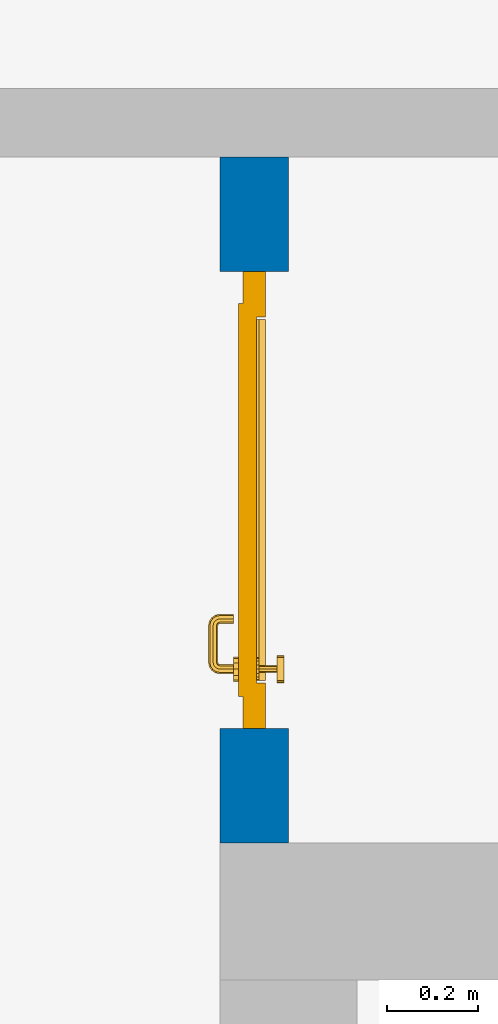
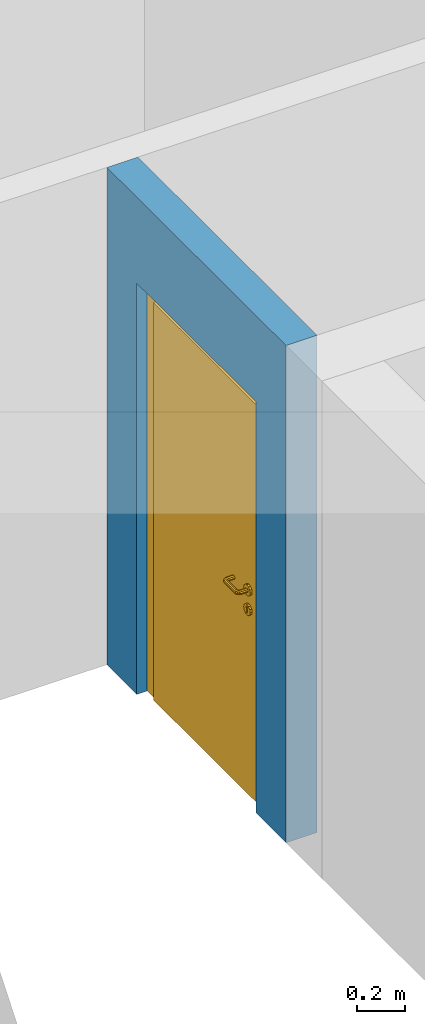
# One storey, part 6 of 54: 1 door, 1 wall, 1 opening.
"""IFC4 building model written with IfcOpenShell, lengths in metres."""

from ifc_helpers import new_model, entity, si_unit, converted_unit, derived_unit, direction, frame, origin_with_axes, place, context, subcontext, project, spatial, polygons, source, transform, mapped, material, type_object, element, fill, save


model = new_model("IFC4")

# Units and contexts
model_context = context("Model", 3, precision=1e-05, world=origin_with_axes(), true_north=direction((0.0, 1.0)))
body_context = subcontext(model_context, "Body", "Model", "MODEL_VIEW")
ifc_project = project(units=[si_unit("LENGTHUNIT", "METRE"), si_unit("AREAUNIT", "SQUARE_METRE"), si_unit("VOLUMEUNIT", "CUBIC_METRE"), converted_unit("PLANEANGLEUNIT", "DEGREE", entity("IfcPlaneAngleMeasure", 0.0174532925199), si_unit("PLANEANGLEUNIT", "RADIAN"), dimensions=[0, 0, 0, 0, 0, 0, 0]), converted_unit("TIMEUNIT", "Year", entity("IfcTimeMeasure", 31556926.0), si_unit("TIMEUNIT", "SECOND"), dimensions=[0, 0, 1, 0, 0, 0, 0]), si_unit("MASSUNIT", "GRAM", prefix="KILO"), si_unit("THERMODYNAMICTEMPERATUREUNIT", "DEGREE_CELSIUS"), si_unit("LUMINOUSINTENSITYUNIT", "LUMEN"), si_unit("ENERGYUNIT", "JOULE", prefix="MEGA"), derived_unit("THERMALCONDUCTANCEUNIT", [(si_unit("POWERUNIT", "WATT"), 1), (si_unit("LENGTHUNIT", "METRE"), -1), (si_unit("THERMODYNAMICTEMPERATUREUNIT", "KELVIN"), -1)]), derived_unit("SPECIFICHEATCAPACITYUNIT", [(si_unit("ENERGYUNIT", "JOULE"), 1), (si_unit("MASSUNIT", "GRAM", prefix="KILO"), -1), (si_unit("THERMODYNAMICTEMPERATUREUNIT", "KELVIN"), -1)]), derived_unit("MASSDENSITYUNIT", [(si_unit("MASSUNIT", "GRAM", prefix="KILO"), 1), (si_unit("VOLUMEUNIT", "CUBIC_METRE"), -1)])], contexts=[model_context])

# Site, building, storey
site_placement = place(None, origin_with_axes())
site = spatial("IfcSite", under=ifc_project, at=site_placement, CompositionType="ELEMENT")
building_placement = place(site_placement, origin_with_axes())
building = spatial("IfcBuilding", under=site, at=building_placement, CompositionType="ELEMENT")
storey_placement = place(building_placement, frame((0.0, 0.0, 6.29), z_axis=(0.0, 0.0, 1.0), x_axis=(1.0, 0.0, 0.0)))
storey = spatial("IfcBuildingStorey", under=building, at=storey_placement, Name="2. Geschoss", CompositionType="ELEMENT", Elevation=6.29)

# Wall, opening, door
ifc_material = material()
wall_type = type_object("IfcWallType", Name="150", PredefinedType="NOTDEFINED")
wall_placement = place(storey_placement, frame((-2.7421993804, 3.67118776896, 0.0), z_axis=(0.0, 0.0, 1.0), x_axis=(0.0, 1.0, 0.0)))
wall = element("IfcWall", 1, at=wall_placement, inside=storey, type_object=wall_type, material=ifc_material, Name="Wand-002", PredefinedType="NOTDEFINED", context=body_context, shape_type="Tessellation", body=[
    polygons([(0.55, -0.15, 2.1), (0.55, 0.0, 2.1), (1.55, 0.0, 2.1), (1.55, -0.15, 2.1), (0.55, -0.1, 0.0), (0.55, 0.0, 0.0), (0.55, -0.15, 0.0), (0.3, 0.0, 0.0), (0.3, 0.0, 2.54), (1.8, 0.0, 2.54), (1.8, 0.0, 0.0), (1.55, 0.0, 0.0), (1.55, -0.1, 0.0), (1.55, -0.15, 0.0), (1.8, -0.15, 2.54), (0.3, -0.15, 2.54), (0.3, -0.15, 0.0), (1.8, -0.15, 0.0)], [[[1, 2, 3, 4]], [[5, 6, 2, 1, 7]], [[2, 6, 8, 9, 10, 11, 12, 3]], [[4, 3, 12, 13, 14]], [[15, 16, 17, 7, 1, 4, 14, 18]], [[6, 5, 7, 17, 8]], [[9, 8, 17, 16]], [[15, 10, 9, 16]], [[15, 18, 11, 10]], [[13, 12, 11, 18, 14]]], closed=True),
])
opening_placement = place(wall_placement, frame((1.05, 0.0, 0.0), z_axis=(0.0, 0.0, 1.0), x_axis=(1.0, 0.0, 0.0)))
opening = element("IfcOpeningElement", 2, at=opening_placement, cuts=wall, context=body_context, identifier="Reference", shape_type="Tessellation", body=[
    polygons([(0.5, -0.1, 0.0), (0.5, -0.1, 2.1), (0.5, -0.151, 2.1), (0.5, -0.151, 0.0), (0.5, 0.001, 0.0), (0.5, 0.001, 2.1), (-0.5, -0.1, 2.1), (-0.5, -0.151, 2.1), (-0.5, 0.001, 2.1), (-0.5, -0.151, 0.0), (-0.5, -0.1, 0.0), (-0.5, 0.001, 0.0)], [[[1, 2, 3, 4]], [[2, 1, 5, 6]], [[7, 8, 3, 2, 6, 9]], [[8, 10, 4, 3]], [[1, 4, 10, 11, 12, 5]], [[6, 5, 12, 9]], [[7, 11, 10, 8]], [[11, 7, 9, 12]]], closed=True),
])
door_type = type_object("IfcDoorType", Name="Eingang 01 1-Fl 26", OperationType="SINGLE_SWING_RIGHT", PredefinedType="DOOR")
shared_shape = source(origin_with_axes(), body_context, "Body", "Tessellation", [
    polygons([(0.5, -0.05, 0.0), (0.5, -0.03, 0.0), (0.5, -0.03, 2.1), (0.5, -0.05, 2.1), (0.4, -0.05, 0.0), (0.4, -0.03, 0.0), (0.4, -0.03, 2.0), (0.1301, -0.03, 2.0), (0.0001, -0.03, 2.0), (-0.4, -0.03, 2.0), (-0.4, -0.03, 0.0), (-0.5, -0.03, 0.0), (-0.5, -0.03, 2.1), (-0.5, -0.05, 2.1), (-0.5, -0.05, 0.0), (-0.4, -0.05, 0.0), (-0.4, -0.05, 2.0), (0.0001, -0.05, 2.0), (0.1301, -0.05, 2.0), (0.4, -0.05, 2.0)], [[[1, 2, 3, 4]], [[5, 6, 2, 1]], [[2, 6, 7, 8, 9, 10, 11, 12, 13, 3]], [[4, 3, 13, 14]], [[1, 4, 14, 15, 16, 17, 18, 19, 20, 5]], [[20, 7, 6, 5]], [[19, 8, 7, 20]], [[18, 9, 8, 19]], [[17, 10, 9, 18]], [[16, 11, 10, 17]], [[15, 12, 11, 16]], [[14, 13, 12, 15]]], closed=True),
    polygons([(0.5, -0.03, 0.0), (0.5, 0.0, 0.0), (0.5, 0.0, 2.1), (0.5, -0.03, 2.1), (0.43, -0.03, 0.0), (0.43, 0.0, 0.0), (0.43, 0.0, 2.03), (0.1001, 0.0, 2.03), (0.0301, 0.0, 2.03), (-0.43, 0.0, 2.03), (-0.43, 0.0, 0.0), (-0.5, 0.0, 0.0), (-0.5, 0.0, 2.1), (-0.5, -0.03, 2.1), (-0.5, -0.03, 0.0), (-0.43, -0.03, 0.0), (-0.43, -0.03, 2.03), (0.0301, -0.03, 2.03), (0.1001, -0.03, 2.03), (0.43, -0.03, 2.03)], [[[1, 2, 3, 4]], [[5, 6, 2, 1]], [[2, 6, 7, 8, 9, 10, 11, 12, 13, 3]], [[4, 3, 13, 14]], [[1, 4, 14, 15, 16, 17, 18, 19, 20, 5]], [[20, 7, 6, 5]], [[19, 8, 7, 20]], [[18, 9, 8, 19]], [[17, 10, 9, 18]], [[16, 11, 10, 17]], [[15, 12, 11, 16]], [[14, 13, 12, 15]]], closed=True),
    polygons([(0.43, 0.01, 0.0), (-0.43, 0.01, 0.0), (-0.43, 0.01, 2.03), (0.43, 0.01, 2.03), (0.43, -0.03, 0.0), (-0.43, -0.03, 0.0), (-0.43, -0.03, 2.03), (0.43, -0.03, 2.03)], [[[1, 2, 3, 4]], [[2, 1, 5, 6]], [[3, 2, 6, 7]], [[4, 3, 7, 8]], [[1, 4, 8, 5]], [[6, 5, 8, 7]]], closed=True),
    polygons([(0.395, -0.05, 0.0), (0.395, -0.05, 0.05), (-0.395, -0.05, 0.05), (-0.395, -0.05, 0.0), (0.395, -0.03, 0.0), (0.395, -0.03, 0.07), (0.395, -0.035, 0.07), (-0.395, -0.035, 0.07), (-0.395, -0.03, 0.07), (-0.395, -0.03, 0.0)], [[[1, 2, 3, 4]], [[1, 5, 6, 7, 2]], [[2, 7, 8, 3]], [[4, 3, 8, 9, 10]], [[5, 1, 4, 10]], [[6, 5, 10, 9]], [[7, 6, 9, 8]]], closed=True),
    polygons([(-0.3835, 0.02, 1.0733826859), (-0.3835, 0.0199, 1.0733826859), (-0.37, 0.0199, 1.077), (-0.37, 0.02, 1.077), (-0.393382685902, 0.02, 1.0635), (-0.393382685902, 0.0199, 1.0635), (-0.3835, 0.0101, 1.0733826859), (-0.37, 0.0101, 1.077), (-0.3565, 0.0199, 1.0733826859), (-0.3565, 0.02, 1.0733826859), (-0.346617314098, 0.02, 1.0635), (-0.343, 0.02, 1.05), (-0.346617314098, 0.02, 1.0365), (-0.3565, 0.02, 1.0266173141), (-0.37, 0.02, 1.023), (-0.3835, 0.02, 1.0266173141), (-0.393382685902, 0.02, 1.0365), (-0.397, 0.02, 1.05), (-0.397, 0.0199, 1.05), (-0.393382685902, 0.0101, 1.0635), (-0.3835, 0.01, 1.0733826859), (-0.37, 0.01, 1.077), (-0.3565, 0.0101, 1.0733826859), (-0.346617314098, 0.0199, 1.0635), (-0.343, 0.0199, 1.05), (-0.346617314098, 0.0199, 1.0365), (-0.3565, 0.0199, 1.0266173141), (-0.37, 0.0199, 1.023), (-0.3835, 0.0199, 1.0266173141), (-0.393382685902, 0.0199, 1.0365), (-0.397, 0.0101, 1.05), (-0.393382685902, 0.01, 1.0635), (-0.397, 0.01, 1.05), (-0.393382685902, 0.01, 1.0365), (-0.3835, 0.01, 1.0266173141), (-0.37, 0.01, 1.023), (-0.3565, 0.01, 1.0266173141), (-0.346617314098, 0.01, 1.0365), (-0.343, 0.01, 1.05), (-0.346617314098, 0.01, 1.0635), (-0.3565, 0.01, 1.0733826859), (-0.346617314098, 0.0101, 1.0635), (-0.343, 0.0101, 1.05), (-0.346617314098, 0.0101, 1.0365), (-0.3565, 0.0101, 1.0266173141), (-0.37, 0.0101, 1.023), (-0.3835, 0.0101, 1.0266173141), (-0.393382685902, 0.0101, 1.0365)], [[[1, 2, 3, 4]], [[5, 6, 2, 1]], [[2, 7, 8, 3]], [[4, 3, 9, 10]], [[4, 10, 11, 12, 13, 14, 15, 16, 17, 18, 5, 1]], [[18, 19, 6, 5]], [[6, 20, 7, 2]], [[7, 21, 22, 8]], [[3, 8, 23, 9]], [[10, 9, 24, 11]], [[11, 24, 25, 12]], [[12, 25, 26, 13]], [[13, 26, 27, 14]], [[14, 27, 28, 15]], [[15, 28, 29, 16]], [[16, 29, 30, 17]], [[17, 30, 19, 18]], [[19, 31, 20, 6]], [[20, 32, 21, 7]], [[22, 21, 32, 33, 34, 35, 36, 37, 38, 39, 40, 41]], [[8, 22, 41, 23]], [[9, 23, 42, 24]], [[24, 42, 43, 25]], [[25, 43, 44, 26]], [[26, 44, 45, 27]], [[27, 45, 46, 28]], [[28, 46, 47, 29]], [[29, 47, 48, 30]], [[30, 48, 31, 19]], [[31, 33, 32, 20]], [[48, 34, 33, 31]], [[47, 35, 34, 48]], [[46, 36, 35, 47]], [[45, 37, 36, 46]], [[44, 38, 37, 45]], [[43, 39, 38, 44]], [[42, 40, 39, 43]], [[23, 41, 40, 42]]], closed=True),
    polygons([(-0.362532169224, 0.019, 0.959692280177), (-0.365, 0.019, 0.9544), (-0.365, 0.019, 0.952886751346), (-0.347569942042, 0.019, 0.96295), (-0.35705, 0.019, 0.972430057958), (-0.363279754556, 0.019, 0.961639806549), (-0.362532169224, 0.02, 0.959692280177), (-0.365, 0.02, 0.9544), (-0.365, 0.02, 0.952886751346), (-0.365, 0.02, 0.95), (-0.365, 0.02, 0.947113248654), (-0.365, 0.02, 0.941339745962), (-0.365, 0.02, 0.9375), (-0.365, 0.019, 0.9375), (-0.365, 0.019, 0.941339745962), (-0.365, 0.019, 0.947113248654), (-0.365, 0.019, 0.95), (-0.3441, 0.019, 0.95), (-0.347483339502, 0.019, 0.963), (-0.357, 0.019, 0.972516660498), (-0.364624817685, 0.019, 0.965143815798), (-0.37, 0.019, 0.9759), (-0.37, 0.019, 0.967425445323), (-0.364624817685, 0.02, 0.965143815798), (-0.363279754556, 0.02, 0.961639806549), (-0.35655, 0.02, 0.973296083362), (-0.346703916638, 0.02, 0.96345), (-0.3431, 0.02, 0.95), (-0.346703916638, 0.02, 0.93655), (-0.35655, 0.02, 0.926703916638), (-0.37, 0.02, 0.9231), (-0.37, 0.02, 0.9325), (-0.366464466094, 0.02, 0.933964466094), (-0.366464466094, 0.019, 0.933964466094), (-0.35705, 0.019, 0.927569942042), (-0.37, 0.019, 0.9325), (-0.37, 0.019, 0.9241), (-0.347569942042, 0.019, 0.93705), (-0.344, 0.019, 0.95), (-0.347483339502, 0.0189, 0.963), (-0.357, 0.0189, 0.972516660498), (-0.37, 0.019, 0.976), (-0.375375182315, 0.019, 0.965143815798), (-0.38295, 0.019, 0.972430057958), (-0.376720245444, 0.019, 0.961639806549), (-0.37, 0.02, 0.967425445323), (-0.37, 0.02, 0.9769), (-0.346617314098, 0.02, 0.9635), (-0.3565, 0.02, 0.973382685902), (-0.343, 0.02, 0.95), (-0.346617314098, 0.02, 0.9365), (-0.3565, 0.02, 0.926617314098), (-0.38345, 0.02, 0.926703916638), (-0.375, 0.02, 0.941339745962), (-0.375, 0.02, 0.9375), (-0.373535533906, 0.02, 0.933964466094), (-0.37, 0.02, 0.923), (-0.373535533906, 0.019, 0.933964466094), (-0.375, 0.019, 0.9375), (-0.375, 0.019, 0.941339745962), (-0.38295, 0.019, 0.927569942042), (-0.37, 0.019, 0.924), (-0.357, 0.019, 0.927483339502), (-0.347483339502, 0.019, 0.937), (-0.344, 0.0189, 0.95), (-0.347483339502, 0.0101, 0.963), (-0.357, 0.0101, 0.972516660498), (-0.37, 0.0189, 0.976), (-0.383, 0.019, 0.972516660498), (-0.375375182315, 0.02, 0.965143815798), (-0.377467830776, 0.019, 0.959692280177), (-0.392430057958, 0.019, 0.96295), (-0.375, 0.019, 0.952886751346), (-0.375, 0.019, 0.9544), (-0.377467830776, 0.02, 0.959692280177), (-0.376720245444, 0.02, 0.961639806549), (-0.38345, 0.02, 0.973296083362), (-0.37, 0.02, 0.977), (-0.346617314098, 0.0199, 0.9635), (-0.3565, 0.0199, 0.973382685902), (-0.343, 0.0199, 0.95), (-0.346617314098, 0.0199, 0.9365), (-0.3565, 0.0199, 0.926617314098), (-0.393296083362, 0.02, 0.93655), (-0.375, 0.02, 0.947113248654), (-0.375, 0.02, 0.9544), (-0.375, 0.019, 0.95), (-0.375, 0.019, 0.947113248654), (-0.375, 0.02, 0.95), (-0.375, 0.02, 0.952886751346), (-0.3835, 0.02, 0.926617314098), (-0.37, 0.0199, 0.923), (-0.392430057958, 0.019, 0.93705), (-0.383, 0.019, 0.927483339502), (-0.37, 0.0189, 0.924), (-0.357, 0.0189, 0.927483339502), (-0.347483339502, 0.0189, 0.937), (-0.344, 0.0101, 0.95), (-0.347483339502, 0.01, 0.963), (-0.357, 0.01, 0.972516660498), (-0.37, 0.0101, 0.976), (-0.383, 0.0189, 0.972516660498), (-0.392516660498, 0.019, 0.963), (-0.3959, 0.019, 0.95), (-0.393296083362, 0.02, 0.96345), (-0.3835, 0.02, 0.973382685902), (-0.37, 0.0199, 0.977), (-0.346617314098, 0.0101, 0.9635), (-0.3565, 0.0101, 0.973382685902), (-0.343, 0.0101, 0.95), (-0.346617314098, 0.0101, 0.9365), (-0.3565, 0.0101, 0.926617314098), (-0.393382685902, 0.02, 0.9365), (-0.3969, 0.02, 0.95), (-0.3835, 0.0199, 0.926617314098), (-0.37, 0.0101, 0.923), (-0.392516660498, 0.019, 0.937), (-0.383, 0.0189, 0.927483339502), (-0.37, 0.0101, 0.924), (-0.357, 0.0101, 0.927483339502), (-0.347483339502, 0.0101, 0.937), (-0.344, 0.01, 0.95), (-0.347396736961, 0.01, 0.96305), (-0.35695, 0.01, 0.972603263039), (-0.37, 0.01, 0.976), (-0.383, 0.0101, 0.972516660498), (-0.392516660498, 0.0189, 0.963), (-0.396, 0.019, 0.95), (-0.393382685902, 0.02, 0.9635), (-0.3835, 0.0199, 0.973382685902), (-0.37, 0.0101, 0.977), (-0.346617314098, 0.01, 0.9635), (-0.3565, 0.01, 0.973382685902), (-0.343, 0.01, 0.95), (-0.346617314098, 0.01, 0.9365), (-0.3565, 0.01, 0.926617314098), (-0.397, 0.02, 0.95), (-0.393382685902, 0.0199, 0.9365), (-0.3835, 0.0101, 0.926617314098), (-0.37, 0.01, 0.923), (-0.392516660498, 0.0189, 0.937), (-0.383, 0.0101, 0.927483339502), (-0.37, 0.01, 0.924), (-0.357, 0.01, 0.927483339502), (-0.347483339502, 0.01, 0.937), (-0.3439, 0.01, 0.95), (-0.346703916638, 0.01, 0.96345), (-0.35655, 0.01, 0.973296083362), (-0.37, 0.01, 0.9761), (-0.383, 0.01, 0.972516660498), (-0.392516660498, 0.0101, 0.963), (-0.396, 0.0189, 0.95), (-0.393382685902, 0.0199, 0.9635), (-0.3835, 0.0101, 0.973382685902), (-0.37, 0.01, 0.977), (-0.3431, 0.01, 0.95), (-0.346703916638, 0.01, 0.93655), (-0.35655, 0.01, 0.926703916638), (-0.397, 0.0199, 0.95), (-0.393382685902, 0.0101, 0.9365), (-0.3835, 0.01, 0.926617314098), (-0.37, 0.01, 0.9231), (-0.392516660498, 0.0101, 0.937), (-0.383, 0.01, 0.927483339502), (-0.37, 0.01, 0.9239), (-0.35695, 0.01, 0.927396736961), (-0.347396736961, 0.01, 0.93695), (-0.37, 0.01, 0.9769), (-0.38305, 0.01, 0.972603263039), (-0.392516660498, 0.01, 0.963), (-0.396, 0.0101, 0.95), (-0.393382685902, 0.0101, 0.9635), (-0.3835, 0.01, 0.973382685902), (-0.397, 0.0101, 0.95), (-0.393382685902, 0.01, 0.9365), (-0.38345, 0.01, 0.926703916638), (-0.392516660498, 0.01, 0.937), (-0.38305, 0.01, 0.927396736961), (-0.38345, 0.01, 0.973296083362), (-0.392603263039, 0.01, 0.96305), (-0.396, 0.01, 0.95), (-0.393382685902, 0.01, 0.9635), (-0.397, 0.01, 0.95), (-0.393296083362, 0.01, 0.93655), (-0.392603263039, 0.01, 0.93695), (-0.393296083362, 0.01, 0.96345), (-0.3961, 0.01, 0.95), (-0.3969, 0.01, 0.95)], [[[1, 2, 3, 4, 5, 6]], [[2, 1, 7, 8]], [[2, 8, 9, 10, 11, 12, 13, 14, 15, 16, 17, 3]], [[17, 18, 4, 3]], [[4, 19, 20, 5]], [[21, 6, 5, 22, 23]], [[1, 6, 21, 24, 25, 7]], [[7, 25, 26, 27, 9, 8]], [[9, 27, 28, 10]], [[10, 28, 29, 11]], [[11, 29, 30, 12]], [[31, 32, 33, 13, 12, 30]], [[14, 13, 33, 34]], [[35, 15, 14, 34, 36, 37]], [[15, 35, 38, 16]], [[16, 38, 18, 17]], [[18, 39, 19, 4]], [[19, 40, 41, 20]], [[5, 20, 42, 22]], [[43, 23, 22, 44, 45]], [[21, 23, 46, 24]], [[24, 46, 47, 26, 25]], [[48, 27, 26, 49]], [[50, 28, 27, 48]], [[51, 29, 28, 50]], [[52, 30, 29, 51]], [[53, 54, 55, 56, 32, 31]], [[34, 33, 32, 36]], [[57, 31, 30, 52]], [[37, 36, 58, 59, 60, 61]], [[37, 62, 63, 35]], [[35, 63, 64, 38]], [[38, 64, 39, 18]], [[39, 65, 40, 19]], [[40, 66, 67, 41]], [[20, 41, 68, 42]], [[22, 42, 69, 44]], [[23, 43, 70, 46]], [[71, 45, 44, 72, 73, 74]], [[43, 45, 71, 75, 76, 70]], [[70, 76, 77, 47, 46]], [[49, 26, 47, 78]], [[79, 48, 49, 80]], [[81, 50, 48, 79]], [[82, 51, 50, 81]], [[83, 52, 51, 82]], [[54, 53, 84, 85]], [[86, 74, 73, 87, 88, 60, 59, 55, 54, 85, 89, 90]], [[58, 56, 55, 59]], [[36, 32, 56, 58]], [[91, 53, 31, 57]], [[92, 57, 52, 83]], [[88, 93, 61, 60]], [[61, 94, 62, 37]], [[62, 95, 96, 63]], [[63, 96, 97, 64]], [[64, 97, 65, 39]], [[65, 98, 66, 40]], [[66, 99, 100, 67]], [[41, 67, 101, 68]], [[42, 68, 102, 69]], [[44, 69, 103, 72]], [[73, 72, 104, 87]], [[71, 74, 86, 75]], [[75, 86, 90, 105, 77, 76]], [[78, 47, 77, 106]], [[80, 49, 78, 107]], [[108, 79, 80, 109]], [[110, 81, 79, 108]], [[111, 82, 81, 110]], [[112, 83, 82, 111]], [[113, 84, 53, 91]], [[85, 84, 114, 89]], [[87, 104, 93, 88]], [[89, 114, 105, 90]], [[115, 91, 57, 92]], [[116, 92, 83, 112]], [[93, 117, 94, 61]], [[94, 118, 95, 62]], [[95, 119, 120, 96]], [[96, 120, 121, 97]], [[97, 121, 98, 65]], [[98, 122, 99, 66]], [[99, 123, 124, 100]], [[67, 100, 125, 101]], [[68, 101, 126, 102]], [[69, 102, 127, 103]], [[72, 103, 128, 104]], [[106, 77, 105, 129]], [[107, 78, 106, 130]], [[109, 80, 107, 131]], [[132, 108, 109, 133]], [[134, 110, 108, 132]], [[135, 111, 110, 134]], [[136, 112, 111, 135]], [[137, 114, 84, 113]], [[138, 113, 91, 115]], [[104, 128, 117, 93]], [[129, 105, 114, 137]], [[139, 115, 92, 116]], [[140, 116, 112, 136]], [[117, 141, 118, 94]], [[118, 142, 119, 95]], [[119, 143, 144, 120]], [[120, 144, 145, 121]], [[121, 145, 122, 98]], [[122, 146, 123, 99]], [[123, 147, 148, 124]], [[100, 124, 149, 125]], [[101, 125, 150, 126]], [[102, 126, 151, 127]], [[103, 127, 152, 128]], [[130, 106, 129, 153]], [[131, 107, 130, 154]], [[133, 109, 131, 155]], [[147, 132, 133, 148]], [[156, 134, 132, 147]], [[157, 135, 134, 156]], [[158, 136, 135, 157]], [[159, 137, 113, 138]], [[160, 138, 115, 139]], [[128, 152, 141, 117]], [[153, 129, 137, 159]], [[161, 139, 116, 140]], [[162, 140, 136, 158]], [[141, 163, 142, 118]], [[142, 164, 143, 119]], [[143, 165, 166, 144]], [[144, 166, 167, 145]], [[145, 167, 146, 122]], [[146, 156, 147, 123]], [[124, 148, 168, 149]], [[125, 149, 169, 150]], [[126, 150, 170, 151]], [[127, 151, 171, 152]], [[154, 130, 153, 172]], [[155, 131, 154, 173]], [[148, 133, 155, 168]], [[167, 157, 156, 146]], [[166, 158, 157, 167]], [[174, 159, 138, 160]], [[175, 160, 139, 161]], [[152, 171, 163, 141]], [[172, 153, 159, 174]], [[176, 161, 140, 162]], [[165, 162, 158, 166]], [[163, 177, 164, 142]], [[164, 178, 165, 143]], [[149, 168, 179, 169]], [[150, 169, 180, 170]], [[151, 170, 181, 171]], [[173, 154, 172, 182]], [[168, 155, 173, 179]], [[183, 174, 160, 175]], [[184, 175, 161, 176]], [[171, 181, 177, 163]], [[182, 172, 174, 183]], [[178, 176, 162, 165]], [[177, 185, 178, 164]], [[169, 179, 186, 180]], [[170, 180, 187, 181]], [[179, 173, 182, 186]], [[188, 183, 175, 184]], [[185, 184, 176, 178]], [[181, 187, 185, 177]], [[186, 182, 183, 188]], [[180, 186, 188, 187]], [[187, 188, 184, 185]]], closed=True),
    polygons([(-0.38, 0.02, 1.05), (-0.38, 0.0509849140336, 1.05), (-0.377071067812, 0.050696439392, 1.04292893219), (-0.377071067812, 0.02, 1.04292893219), (-0.377071067812, 0.02, 1.05707106781), (-0.377071067812, 0.050696439392, 1.05707106781), (-0.378277987014, 0.0596420579258, 1.05), (-0.375518993221, 0.0584992452783, 1.04292893219), (-0.37, 0.05, 1.04), (-0.37, 0.02, 1.04), (-0.37, 0.02, 1.06), (-0.37, 0.05, 1.06), (-0.375518993221, 0.0584992452783, 1.05707106781), (-0.372816199938, 0.0678161999379, 1.05), (-0.370704557509, 0.0657045575088, 1.04292893219), (-0.368858192988, 0.0557402514855, 1.04), (-0.362928932188, 0.049303560608, 1.04292893219), (-0.362928932188, 0.02, 1.04292893219), (-0.362928932188, 0.02, 1.05707106781), (-0.362928932188, 0.049303560608, 1.05707106781), (-0.368858192988, 0.0557402514855, 1.06), (-0.370704557509, 0.0657045575088, 1.05707106781), (-0.364642057926, 0.0732779870137, 1.05), (-0.363499245278, 0.0705189932208, 1.04292893219), (-0.365606601718, 0.0606066017178, 1.04), (-0.362197392755, 0.0529812576926, 1.04292893219), (-0.36, 0.0490150859664, 1.05), (-0.36, 0.02, 1.05), (-0.362197392755, 0.0529812576926, 1.05707106781), (-0.365606601718, 0.0606066017178, 1.06), (-0.363499245278, 0.0705189932208, 1.05707106781), (-0.355984914034, 0.075, 1.05), (-0.355696439392, 0.0720710678119, 1.04292893219), (-0.360740251485, 0.0638581929877, 1.04), (-0.360508645927, 0.0555086459268, 1.04292893219), (-0.359438398962, 0.0518384450452, 1.05), (-0.360508645927, 0.0555086459268, 1.05707106781), (-0.360740251485, 0.0638581929877, 1.06), (-0.355696439392, 0.0720710678119, 1.05707106781), (-0.274015085966, 0.075, 1.05), (-0.274303560608, 0.0720710678119, 1.04292893219), (-0.355, 0.065, 1.04), (-0.357981257693, 0.0571973927545, 1.04292893219), (-0.358397003498, 0.0533970034977, 1.05), (-0.357981257693, 0.0571973927545, 1.05707106781), (-0.355, 0.065, 1.06), (-0.274303560608, 0.0720710678119, 1.05707106781), (-0.265357942074, 0.0732779870137, 1.05), (-0.266500754722, 0.0705189932208, 1.04292893219), (-0.275, 0.065, 1.04), (-0.354303560608, 0.0579289321881, 1.04292893219), (-0.356838445045, 0.0544383989617, 1.05), (-0.354303560608, 0.0579289321881, 1.05707106781), (-0.275, 0.065, 1.06), (-0.266500754722, 0.0705189932208, 1.05707106781), (-0.257183800062, 0.0678161999379, 1.05), (-0.259295442491, 0.0657045575088, 1.04292893219), (-0.269259748515, 0.0638581929877, 1.04), (-0.275696439392, 0.0579289321881, 1.04292893219), (-0.354015085966, 0.055, 1.05), (-0.275696439392, 0.0579289321881, 1.05707106781), (-0.269259748515, 0.0638581929877, 1.06), (-0.259295442491, 0.0657045575088, 1.05707106781), (-0.251722012986, 0.0596420579258, 1.05), (-0.254481006779, 0.0584992452783, 1.04292893219), (-0.264393398282, 0.0606066017178, 1.04), (-0.272018742307, 0.0571973927545, 1.04292893219), (-0.275984914034, 0.055, 1.05), (-0.272018742307, 0.0571973927545, 1.05707106781), (-0.264393398282, 0.0606066017178, 1.06), (-0.254481006779, 0.0584992452783, 1.05707106781), (-0.25, 0.0509849140336, 1.05), (-0.252928932188, 0.050696439392, 1.04292893219), (-0.261141807012, 0.0557402514855, 1.04), (-0.269491354073, 0.0555086459268, 1.04292893219), (-0.273161554955, 0.0544383989617, 1.05), (-0.269491354073, 0.0555086459268, 1.05707106781), (-0.261141807012, 0.0557402514855, 1.06), (-0.252928932188, 0.050696439392, 1.05707106781), (-0.25, 0.02, 1.05), (-0.252928932188, 0.02, 1.04292893219), (-0.26, 0.05, 1.04), (-0.267802607245, 0.0529812576926, 1.04292893219), (-0.271602996502, 0.0533970034977, 1.05), (-0.267802607245, 0.0529812576926, 1.05707106781), (-0.26, 0.05, 1.06), (-0.252928932188, 0.02, 1.05707106781), (-0.26, 0.02, 1.06), (-0.267071067812, 0.02, 1.05707106781), (-0.27, 0.02, 1.05), (-0.267071067812, 0.02, 1.04292893219), (-0.26, 0.02, 1.04), (-0.267071067812, 0.049303560608, 1.04292893219), (-0.270561601038, 0.0518384450452, 1.05), (-0.267071067812, 0.049303560608, 1.05707106781), (-0.27, 0.0490150859664, 1.05)], [[[1, 2, 3, 4]], [[5, 6, 2, 1]], [[2, 7, 8, 3]], [[4, 3, 9, 10]], [[11, 12, 6, 5]], [[6, 13, 7, 2]], [[7, 14, 15, 8]], [[3, 8, 16, 9]], [[10, 9, 17, 18]], [[19, 20, 12, 11]], [[12, 21, 13, 6]], [[13, 22, 14, 7]], [[14, 23, 24, 15]], [[8, 15, 25, 16]], [[9, 16, 26, 17]], [[18, 17, 27, 28]], [[28, 27, 20, 19]], [[20, 29, 21, 12]], [[21, 30, 22, 13]], [[22, 31, 23, 14]], [[23, 32, 33, 24]], [[15, 24, 34, 25]], [[16, 25, 35, 26]], [[17, 26, 36, 27]], [[27, 36, 29, 20]], [[29, 37, 30, 21]], [[30, 38, 31, 22]], [[31, 39, 32, 23]], [[32, 40, 41, 33]], [[24, 33, 42, 34]], [[25, 34, 43, 35]], [[26, 35, 44, 36]], [[36, 44, 37, 29]], [[37, 45, 38, 30]], [[38, 46, 39, 31]], [[39, 47, 40, 32]], [[40, 48, 49, 41]], [[33, 41, 50, 42]], [[34, 42, 51, 43]], [[35, 43, 52, 44]], [[44, 52, 45, 37]], [[45, 53, 46, 38]], [[46, 54, 47, 39]], [[47, 55, 48, 40]], [[48, 56, 57, 49]], [[41, 49, 58, 50]], [[42, 50, 59, 51]], [[43, 51, 60, 52]], [[52, 60, 53, 45]], [[53, 61, 54, 46]], [[54, 62, 55, 47]], [[55, 63, 56, 48]], [[56, 64, 65, 57]], [[49, 57, 66, 58]], [[50, 58, 67, 59]], [[51, 59, 68, 60]], [[60, 68, 61, 53]], [[61, 69, 62, 54]], [[62, 70, 63, 55]], [[63, 71, 64, 56]], [[64, 72, 73, 65]], [[57, 65, 74, 66]], [[58, 66, 75, 67]], [[59, 67, 76, 68]], [[68, 76, 69, 61]], [[69, 77, 70, 62]], [[70, 78, 71, 63]], [[71, 79, 72, 64]], [[72, 80, 81, 73]], [[65, 73, 82, 74]], [[66, 74, 83, 75]], [[67, 75, 84, 76]], [[76, 84, 77, 69]], [[77, 85, 78, 70]], [[78, 86, 79, 71]], [[79, 87, 80, 72]], [[80, 87, 88, 89, 90, 91, 92, 81]], [[73, 81, 92, 82]], [[74, 82, 93, 83]], [[75, 83, 94, 84]], [[84, 94, 85, 77]], [[85, 95, 86, 78]], [[86, 88, 87, 79]], [[95, 89, 88, 86]], [[96, 90, 89, 95]], [[93, 91, 90, 96]], [[82, 92, 91, 93]], [[83, 93, 96, 94]], [[94, 96, 95, 85]]], closed=False),
    polygons([(-0.364696699141, -0.035, 1.04469669914), (-0.37, -0.035, 1.0425), (-0.375303300859, -0.035, 1.04469669914), (-0.3775, -0.035, 1.05), (-0.375303300859, -0.035, 1.05530330086), (-0.37, -0.035, 1.0575), (-0.364696699141, -0.035, 1.05530330086), (-0.3625, -0.035, 1.05), (-0.364696699141, -0.075, 1.04469669914), (-0.37, -0.075, 1.0425), (-0.375303300859, -0.075, 1.04469669914), (-0.3775, -0.075, 1.05), (-0.375303300859, -0.075, 1.05530330086), (-0.37, -0.075, 1.0575), (-0.364696699141, -0.075, 1.05530330086), (-0.3625, -0.075, 1.05)], [[[1, 2, 3, 4, 5, 6, 7, 8]], [[2, 1, 9, 10]], [[3, 2, 10, 11]], [[4, 3, 11, 12]], [[5, 4, 12, 13]], [[6, 5, 13, 14]], [[7, 6, 14, 15]], [[8, 7, 15, 16]], [[1, 8, 16, 9]], [[9, 16, 15, 14, 13, 12, 11, 10]]], closed=True),
    polygons([(-0.395, -0.03, 0.975), (-0.393096988313, -0.03, 0.965432914191), (-0.393096988313, -0.035, 0.965432914191), (-0.395, -0.035, 0.975), (-0.395, -0.03, 1.1), (-0.393096988313, -0.03, 1.10956708581), (-0.38767766953, -0.03, 1.11767766953), (-0.379567085809, -0.03, 1.12309698831), (-0.37, -0.03, 1.125), (-0.360432914191, -0.03, 1.12309698831), (-0.35232233047, -0.03, 1.11767766953), (-0.346903011687, -0.03, 1.10956708581), (-0.345, -0.03, 1.1), (-0.345, -0.03, 0.975), (-0.346903011687, -0.03, 0.965432914191), (-0.35232233047, -0.03, 0.95732233047), (-0.360432914191, -0.03, 0.951903011687), (-0.37, -0.03, 0.95), (-0.379567085809, -0.03, 0.951903011687), (-0.38767766953, -0.03, 0.95732233047), (-0.38767766953, -0.035, 0.95732233047), (-0.379567085809, -0.035, 0.951903011687), (-0.37, -0.035, 0.95), (-0.360432914191, -0.035, 0.951903011687), (-0.35232233047, -0.035, 0.95732233047), (-0.346903011687, -0.035, 0.965432914191), (-0.345, -0.035, 0.975), (-0.345, -0.035, 1.1), (-0.346903011687, -0.035, 1.10956708581), (-0.35232233047, -0.035, 1.11767766953), (-0.360432914191, -0.035, 1.12309698831), (-0.37, -0.035, 1.125), (-0.379567085809, -0.035, 1.12309698831), (-0.38767766953, -0.035, 1.11767766953), (-0.393096988313, -0.035, 1.10956708581), (-0.395, -0.035, 1.1)], [[[1, 2, 3, 4]], [[1, 5, 6, 7, 8, 9, 10, 11, 12, 13, 14, 15, 16, 17, 18, 19, 20, 2]], [[2, 20, 21, 3]], [[4, 3, 21, 22, 23, 24, 25, 26, 27, 28, 29, 30, 31, 32, 33, 34, 35, 36]], [[5, 1, 4, 36]], [[6, 5, 36, 35]], [[7, 6, 35, 34]], [[8, 7, 34, 33]], [[9, 8, 33, 32]], [[10, 9, 32, 31]], [[11, 10, 31, 30]], [[12, 11, 30, 29]], [[13, 12, 29, 28]], [[14, 13, 28, 27]], [[15, 14, 27, 26]], [[16, 15, 26, 25]], [[17, 16, 25, 24]], [[18, 17, 24, 23]], [[19, 18, 23, 22]], [[20, 19, 22, 21]]], closed=True),
    polygons([(-0.39, -0.075, 1.08), (-0.395, -0.075, 1.07866025404), (-0.395, -0.09, 1.07866025404), (-0.39, -0.09, 1.08), (-0.35, -0.075, 1.08), (-0.345, -0.075, 1.07866025404), (-0.341339745962, -0.075, 1.075), (-0.34, -0.075, 1.07), (-0.34, -0.075, 1.03), (-0.341339745962, -0.075, 1.025), (-0.345, -0.075, 1.02133974596), (-0.35, -0.075, 1.02), (-0.39, -0.075, 1.02), (-0.395, -0.075, 1.02133974596), (-0.398660254038, -0.075, 1.025), (-0.4, -0.075, 1.03), (-0.4, -0.075, 1.07), (-0.398660254038, -0.075, 1.075), (-0.398660254038, -0.09, 1.075), (-0.4, -0.09, 1.07), (-0.4, -0.09, 1.03), (-0.398660254038, -0.09, 1.025), (-0.395, -0.09, 1.02133974596), (-0.39, -0.09, 1.02), (-0.35, -0.09, 1.02), (-0.345, -0.09, 1.02133974596), (-0.341339745962, -0.09, 1.025), (-0.34, -0.09, 1.03), (-0.34, -0.09, 1.07), (-0.341339745962, -0.09, 1.075), (-0.345, -0.09, 1.07866025404), (-0.35, -0.09, 1.08)], [[[1, 2, 3, 4]], [[1, 5, 6, 7, 8, 9, 10, 11, 12, 13, 14, 15, 16, 17, 18, 2]], [[2, 18, 19, 3]], [[4, 3, 19, 20, 21, 22, 23, 24, 25, 26, 27, 28, 29, 30, 31, 32]], [[5, 1, 4, 32]], [[6, 5, 32, 31]], [[7, 6, 31, 30]], [[8, 7, 30, 29]], [[9, 8, 29, 28]], [[10, 9, 28, 27]], [[11, 10, 27, 26]], [[12, 11, 26, 25]], [[13, 12, 25, 24]], [[14, 13, 24, 23]], [[15, 14, 23, 22]], [[16, 15, 22, 21]], [[17, 16, 21, 20]], [[18, 17, 20, 19]]], closed=True),
])
door_placement = place(opening_placement, frame((-0.4, 0.0, 0.0), z_axis=(0.0, 0.0, 1.0), x_axis=(1.0, 0.0, 0.0)))
door = element("IfcDoor", 3, at=door_placement, inside=storey, type_object=door_type, OverallHeight=2.1, OverallWidth=1.0, PredefinedType="DOOR", context=body_context, shape_type="MappedRepresentation", body=[
    mapped(shared_shape, transform((0.4, -0.05, 0.0))),
])
fill(opening, door)

save(model, "model.ifc")
